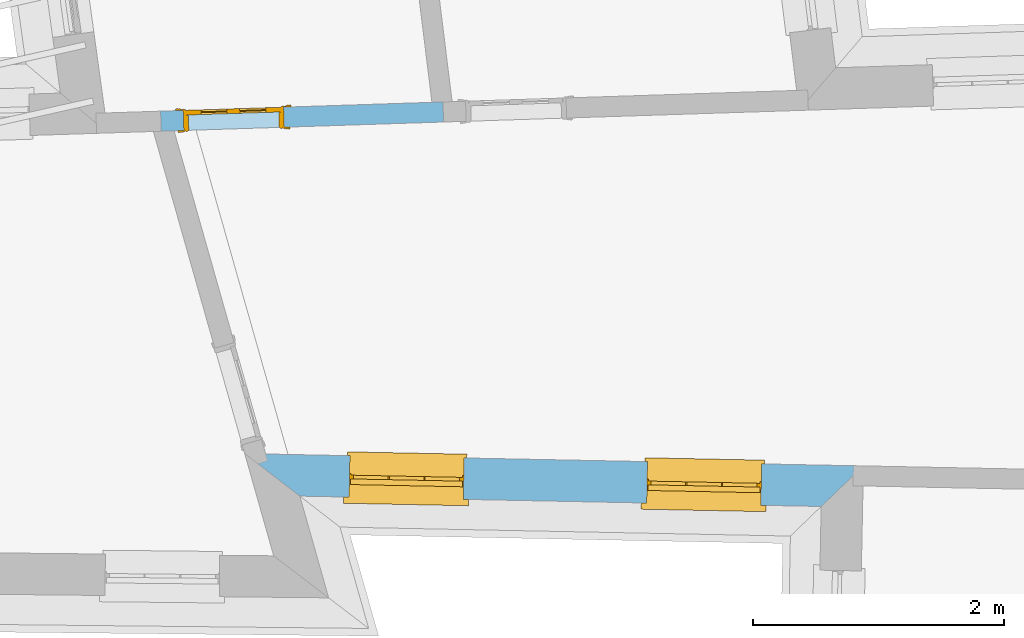
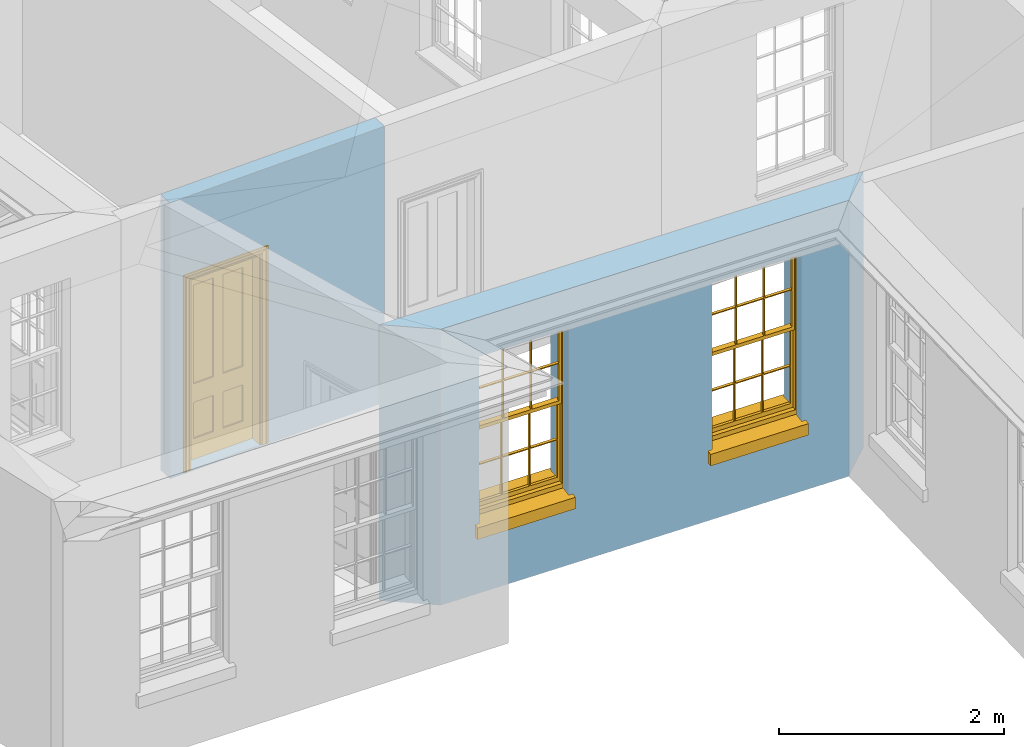
# One storey, part 4 of 11: 2 windows, 1 door, 3 openings, plus 2 elements that do not belong to this part.
"""IFC2X3 building model written with IfcOpenShell, lengths in metres."""

from ifc_helpers import new_model, si_unit, frame, origin, place, context, subcontext, project, spatial, polyline, outline, extrude, faceted_brep, material, layer, layer_set, layer_usage, element, fill, save


model = new_model("IFC2X3")

# Units and contexts
model_context = context("Model", 3, world=origin())
body_context = subcontext(model_context, "Body", "Model", "MODEL_VIEW")
ifc_project = project(units=[si_unit("PLANEANGLEUNIT", "RADIAN"), si_unit("MASSUNIT", "GRAM", prefix="KILO"), si_unit("FORCEUNIT", "NEWTON", prefix="KILO"), si_unit("LENGTHUNIT", "METRE")], contexts=[model_context])

# Site, building, storey
site_placement = place(None, origin())
site = spatial("IfcSite", under=ifc_project, at=site_placement, CompositionType="ELEMENT")
building_placement = place(None, origin())
building = spatial("IfcBuilding", under=site, at=building_placement, Name="Building plot-10", CompositionType="ELEMENT")
storey_placement = place(None, frame((0.0, 0.0, 4.6)))
storey = spatial("IfcBuildingStorey", under=building, at=storey_placement, Name="Floor 1", CompositionType="ELEMENT", Elevation=4.6)

# Wall, openings, windows
ifc_material_1 = material(Name="Masonry")
ifc_layer_1 = layer(ifc_material_1, 0.33, ventilated=False)
ifc_layer_set_1 = layer_set([ifc_layer_1], Name="My Wall")
ifc_layer_usage_1 = layer_usage(ifc_layer_set_1, "AXIS2", "NEGATIVE", 0.08)
wall_1_placement = place(storey_placement, origin())
wall_1 = element("IfcWallStandardCase", 1, at=wall_1_placement, inside=storey, material=ifc_layer_usage_1, Name="exterior", context=body_context, shape_type="SweptSolid", body=[
    extrude(outline(polyline([(46.0806293719887, 17.3535320709695), (46.5196877486523, 17.0147171959322), (50.6688922402643, 16.9320337058085), (51.0054015240496, 17.2553934156152), (46.0806293719887, 17.3535320709695)])), origin(), (0.0, 0.0, 1.0), 3.0),
])
opening_1_placement = place(storey_placement, frame((0.0, 0.0, 0.75)))
opening_1 = element("IfcOpeningElement", 2, at=opening_1_placement, cuts=wall_1, Name="Opening", ObjectType="Opening", context=body_context, shape_type="SweptSolid", body=[
    extrude(outline(polyline([(46.9113661195027, 17.0069120046544), (47.8211854894554, 16.9887815314415), (47.8277602764447, 17.3187160282375), (46.917940906492, 17.3368465014504), (46.9113661195027, 17.0069120046544)])), origin(), (0.0, 0.0, 1.0), 1.82),
])
opening_2_placement = place(storey_placement, frame((0.0, 0.0, 0.75)))
opening_2 = element("IfcOpeningElement", 3, at=opening_2_placement, cuts=wall_1, Name="Opening", ObjectType="Opening", context=body_context, shape_type="SweptSolid", body=[
    extrude(outline(polyline([(49.2797439942666, 16.9597160303385), (50.1895633642193, 16.9415855571257), (50.1961381512086, 17.2715200539217), (49.2863187812559, 17.2896505271346), (49.2797439942666, 16.9597160303385)])), origin(), (0.0, 0.0, 1.0), 1.82),
])
window_1_placement = place(storey_placement, frame((46.916347018737, 17.256862381015, 0.75), z_axis=(0.0, 0.0, 1.0), x_axis=(0.909819369952672, -0.0181304732128638, 0.0)))
window_1 = element("IfcWindow", 4, at=window_1_placement, inside=storey, Name="circulation outside window", OverallHeight=1.82, OverallWidth=0.91, context=body_context, shape_type="Brep", held_by="IfcProductRepresentation", body=[
    faceted_brep([(0.033125, -0.105, 0.975209), (0.01, -0.105, 0.975209), (0.033125, -0.105, 1.376042), (0.876875, -0.105, 0.975209), (0.876875, -0.105, 1.376042), (0.9, -0.105, 0.975209), (0.876875, -0.105, 1.386042), (0.876875, -0.105, 1.786875), (0.9, -0.105, 1.81), (0.033125, -0.105, 1.786875), (0.033125, -0.105, 1.386042), (0.01, -0.105, 1.81), (0.876875, -0.135, 1.376042), (0.876875, -0.135, 0.975209), (0.9, -0.135, 0.937083), (0.033125, -0.135, 1.786875), (0.01, -0.135, 1.81), (0.033125, -0.135, 1.386042), (0.01, -0.135, 0.937083), (0.033125, -0.135, 0.975209), (0.033125, -0.135, 1.376042), (0.876875, -0.135, 1.786875), (0.876875, -0.135, 1.386042), (0.9, -0.135, 1.81), (0.033125, -0.105, 0.937083), (0.01, -0.105, 0.937083), (0.033125, -0.105, 0.53625), (0.876875, -0.105, 0.937083), (0.876875, -0.105, 0.53625), (0.9, -0.105, 0.937083), (0.876875, -0.105, 0.52625), (0.876875, -0.105, 0.125417), (0.9, -0.105, 0.077167), (0.033125, -0.105, 0.125417), (0.033125, -0.105, 0.52625), (0.01, -0.105, 0.077167), (-0.0425, -0.25, 0.01), (-0.0425, -0.3, 0.001667), (0.0, -0.25, 0.01), (0.9525, -0.25, 0.01), (0.91, -0.25, 0.01), (0.9525, -0.3, 0.001667), (-0.02, 0.08, 0.077167), (0.0, 0.08, 0.077167), (-0.02, 0.11, 0.077167), (0.0, -0.06, 0.077167), (0.01, -0.06, 0.077167), (0.91, -0.06, 0.077167), (0.91, 0.08, 0.077167), (0.9, -0.06, 0.077167), (0.93, 0.08, 0.077167), (0.93, 0.11, 0.077167), (0.01, -0.075, 0.975209), (0.9, -0.075, 0.975209), (0.876875, -0.075, 0.125417), (0.876875, -0.075, 0.52625), (0.9, -0.075, 0.077167), (0.876875, -0.075, 0.53625), (0.876875, -0.075, 0.937083), (0.033125, -0.075, 0.125417), (0.01, -0.075, 0.077167), (0.033125, -0.075, 0.52625), (0.033125, -0.075, 0.937083), (0.033125, -0.075, 0.53625), (-0.02, 0.08, 0.052167), (-0.02, 0.11, 0.052167), (0.93, 0.11, 0.052167), (0.93, 0.08, 0.052167), (0.91, 0.08, 0.052167), (0.0, 0.08, 0.052167), (0.91, -0.15, 0.026667), (0.0, -0.15, 0.026667), (-0.0425, -0.3, -0.123333), (0.9525, -0.3, -0.123333), (-0.0425, -0.25, -0.123333), (0.9525, -0.25, -0.123333), (0.01, -0.06, 1.81), (0.9, -0.06, 1.81), (0.0, -0.06, 1.82), (0.91, -0.06, 1.82), (0.01, -0.15, 0.077167), (0.9, -0.15, 0.077167), (0.592292, -0.105, 0.125417), (0.592292, -0.075, 0.125417), (0.317708, -0.075, 0.125417), (0.317708, -0.105, 0.125417), (0.592292, -0.105, 0.53625), (0.317708, -0.105, 0.53625), (0.317708, -0.105, 0.52625), (0.592292, -0.105, 0.52625), (0.592292, -0.075, 0.53625), (0.317708, -0.075, 0.53625), (0.592292, -0.135, 1.386042), (0.592292, -0.105, 1.386042), (0.317708, -0.105, 1.386042), (0.317708, -0.135, 1.386042), (0.317708, -0.135, 1.376042), (0.592292, -0.135, 1.376042), (0.317708, -0.105, 1.376042), (0.592292, -0.105, 1.376042), (0.602292, -0.135, 1.376042), (0.592292, -0.135, 0.975209), (0.602292, -0.135, 0.975209), (0.602292, -0.105, 0.975209), (0.592292, -0.105, 0.975209), (0.602292, -0.105, 1.376042), (0.602292, -0.075, 0.53625), (0.602292, -0.105, 0.53625), (0.317708, -0.075, 0.52625), (0.307708, -0.075, 0.125417), (0.307708, -0.075, 0.52625), (0.602292, -0.075, 0.52625), (0.602292, -0.075, 0.125417), (0.592292, -0.075, 0.52625), (0.307708, -0.075, 0.53625), (0.317708, -0.075, 0.937083), (0.307708, -0.075, 0.937083), (0.602292, -0.075, 0.937083), (0.592292, -0.075, 0.937083), (0.307708, -0.105, 0.52625), (0.307708, -0.105, 0.125417), (0.307708, -0.105, 0.53625), (0.307708, -0.105, 0.937083), (0.592292, -0.105, 0.937083), (0.317708, -0.105, 0.937083), (0.602292, -0.105, 0.937083), (0.602292, -0.105, 0.52625), (0.602292, -0.105, 0.125417), (0.307708, -0.135, 1.386042), (0.307708, -0.135, 1.376042), (0.307708, -0.135, 0.975209), (0.317708, -0.135, 0.975209), (0.317708, -0.135, 1.786875), (0.307708, -0.135, 1.786875), (0.602292, -0.135, 1.786875), (0.592292, -0.135, 1.786875), (0.602292, -0.135, 1.386042), (0.602292, -0.105, 1.386042), (0.307708, -0.105, 1.386042), (0.307708, -0.105, 1.786875), (0.317708, -0.105, 1.786875), (0.592292, -0.105, 1.786875), (0.602292, -0.105, 1.786875), (0.307708, -0.105, 1.376042), (0.317708, -0.105, 0.975209), (0.307708, -0.105, 0.975209), (0.91, -0.15, 1.82), (0.9, -0.15, 1.81), (0.01, -0.15, 1.81), (0.0, -0.15, 1.82), (0.91, -0.25, 0.0), (0.0, -0.25, 0.0), (0.91, 0.08, 0.0), (0.0, 0.08, 0.0)], [[[0, 1, 2]], [[3, 4, 5]], [[6, 7, 8]], [[9, 10, 11]], [[12, 13, 14]], [[15, 16, 17]], [[18, 19, 20]], [[21, 22, 23]], [[24, 25, 26]], [[27, 28, 29]], [[30, 31, 32]], [[33, 34, 35]], [[14, 27, 29]], [[25, 24, 18]], [[36, 37, 38]], [[39, 40, 41]], [[42, 43, 44]], [[45, 46, 43]], [[47, 48, 49]], [[50, 51, 48]], [[1, 0, 52]], [[5, 53, 3]], [[54, 55, 56]], [[57, 58, 53]], [[59, 60, 61]], [[62, 63, 52]], [[48, 43, 46, 49]], [[51, 44, 43, 48]], [[64, 42, 44, 65]], [[65, 44, 51, 66]], [[66, 51, 50, 67]], [[65, 66, 68, 69]], [[60, 56, 49, 46]], [[70, 71, 38, 40]], [[37, 41, 40, 38]], [[37, 72, 73, 41]], [[74, 75, 73, 72]], [[8, 11, 76, 77]], [[76, 78, 79, 77]], [[32, 35, 80, 81]], [[81, 80, 71, 70]], [[82, 83, 84, 85]], [[86, 87, 88, 89]], [[86, 90, 91, 87]], [[92, 93, 94, 95]], [[92, 95, 96, 97]], [[96, 98, 99, 97]], [[100, 97, 101, 102]], [[103, 104, 99, 105]], [[97, 99, 104, 101]], [[102, 103, 105, 100]], [[28, 57, 106, 107]], [[108, 84, 109, 110]], [[111, 112, 83, 113]], [[114, 110, 61, 63]], [[90, 113, 108, 91]], [[115, 91, 114, 116]], [[117, 106, 90, 118]], [[111, 106, 57, 55]], [[119, 110, 109, 120]], [[34, 61, 110, 119]], [[89, 113, 83, 82]], [[88, 108, 113, 89]], [[85, 84, 108, 88]], [[121, 114, 63, 26]], [[122, 116, 114, 121]], [[123, 118, 90, 86]], [[87, 91, 115, 124]], [[107, 106, 117, 125]], [[126, 111, 55, 30]], [[127, 112, 111, 126]], [[126, 30, 28, 107]], [[88, 119, 120, 85]], [[126, 89, 82, 127]], [[125, 123, 86, 107]], [[121, 26, 34, 119]], [[124, 122, 121, 87]], [[128, 17, 20, 129]], [[96, 129, 130, 131]], [[132, 133, 128, 95]], [[134, 135, 92, 136]], [[100, 12, 22, 136]], [[137, 6, 4, 105]], [[94, 138, 139, 140]], [[137, 93, 141, 142]], [[99, 98, 94, 93]], [[143, 2, 10, 138]], [[144, 145, 143, 98]], [[129, 143, 145, 130]], [[20, 2, 143, 129]], [[131, 144, 98, 96]], [[128, 138, 10, 17]], [[133, 139, 138, 128]], [[135, 141, 93, 92]], [[95, 94, 140, 132]], [[22, 6, 137, 136]], [[136, 137, 142, 134]], [[100, 105, 4, 12]], [[107, 86, 89, 126]], [[106, 111, 113, 90]], [[91, 108, 110, 114]], [[87, 121, 119, 88]], [[97, 100, 136, 92]], [[129, 96, 95, 128]], [[98, 143, 138, 94]], [[105, 99, 93, 137]], [[131, 101, 104, 144]], [[124, 115, 118, 123]], [[132, 140, 141, 135]], [[120, 109, 59, 33]], [[15, 9, 139, 133]], [[134, 142, 7, 21]], [[31, 54, 112, 127]], [[36, 74, 72, 37]], [[39, 41, 73, 75]], [[18, 14, 101, 131]], [[23, 16, 132, 135]], [[83, 56, 60, 84]], [[52, 53, 118, 115]], [[53, 52, 144, 104]], [[11, 8, 141, 140]], [[14, 18, 124, 123]], [[2, 1, 11, 10]], [[8, 5, 4, 6]], [[57, 53, 56, 55]], [[60, 52, 63, 61]], [[26, 25, 35, 34]], [[32, 29, 28, 30]], [[14, 23, 22, 12]], [[18, 20, 17, 16]], [[19, 0, 2, 20]], [[17, 10, 9, 15]], [[12, 4, 3, 13]], [[21, 7, 6, 22]], [[27, 58, 57, 28]], [[30, 55, 54, 31]], [[33, 59, 61, 34]], [[26, 63, 62, 24]], [[5, 8, 77, 53]], [[76, 11, 1, 52]], [[46, 45, 78, 76]], [[49, 77, 79, 47]], [[70, 146, 147, 81]], [[71, 80, 148, 149]], [[19, 130, 145, 0]], [[102, 13, 3, 103]], [[116, 122, 24, 62]], [[29, 32, 81, 14]], [[80, 35, 25, 18]], [[60, 46, 76, 52]], [[77, 49, 56, 53]], [[23, 14, 81, 147]], [[16, 148, 80, 18]], [[35, 85, 120]], [[120, 33, 35]], [[127, 82, 32]], [[32, 31, 127]], [[32, 82, 85, 35]], [[102, 101, 14]], [[14, 13, 102]], [[18, 131, 130]], [[130, 19, 18]], [[134, 21, 23]], [[23, 135, 134]], [[16, 15, 133]], [[133, 132, 16]], [[11, 140, 139]], [[139, 9, 11]], [[142, 141, 8]], [[8, 7, 142]], [[23, 147, 148, 16]], [[146, 149, 148, 147]], [[52, 115, 116]], [[116, 62, 52]], [[118, 53, 117]], [[58, 117, 53]], [[27, 125, 117, 58]], [[56, 83, 112]], [[112, 54, 56]], [[109, 84, 60]], [[60, 59, 109]], [[125, 27, 14]], [[14, 123, 125]], [[122, 124, 18]], [[18, 24, 122]], [[145, 144, 52]], [[52, 0, 145]], [[103, 3, 53]], [[53, 104, 103]], [[79, 78, 149, 146]], [[78, 45, 71, 149]], [[146, 70, 47, 79]], [[150, 75, 74, 151]], [[68, 66, 67]], [[48, 68, 67, 50]], [[69, 64, 65]], [[42, 64, 69, 43]], [[69, 68, 152, 153]], [[70, 68, 48, 47]], [[150, 152, 68, 70]], [[43, 69, 71, 45]], [[69, 153, 151, 71]], [[152, 150, 151, 153]], [[38, 151, 74, 36]], [[71, 151, 38]], [[39, 75, 150, 40]], [[40, 150, 70]]]),
])
fill(opening_1, window_1)
window_2_placement = place(storey_placement, frame((49.2847248935009, 17.2096664066992, 0.75), z_axis=(0.0, 0.0, 1.0), x_axis=(0.909819369952672, -0.0181304732128638, 0.0)))
window_2 = element("IfcWindow", 5, at=window_2_placement, inside=storey, Name="circulation outside window", OverallHeight=1.82, OverallWidth=0.91, context=body_context, shape_type="Brep", held_by="IfcProductRepresentation", body=[
    faceted_brep([(0.033125, -0.105, 0.975209), (0.01, -0.105, 0.975209), (0.033125, -0.105, 1.376042), (0.876875, -0.105, 0.975209), (0.876875, -0.105, 1.376042), (0.9, -0.105, 0.975209), (0.876875, -0.105, 1.386042), (0.876875, -0.105, 1.786875), (0.9, -0.105, 1.81), (0.033125, -0.105, 1.786875), (0.033125, -0.105, 1.386042), (0.01, -0.105, 1.81), (0.876875, -0.135, 1.376042), (0.876875, -0.135, 0.975209), (0.9, -0.135, 0.937083), (0.033125, -0.135, 1.786875), (0.01, -0.135, 1.81), (0.033125, -0.135, 1.386042), (0.01, -0.135, 0.937083), (0.033125, -0.135, 0.975209), (0.033125, -0.135, 1.376042), (0.876875, -0.135, 1.786875), (0.876875, -0.135, 1.386042), (0.9, -0.135, 1.81), (0.033125, -0.105, 0.937083), (0.01, -0.105, 0.937083), (0.033125, -0.105, 0.53625), (0.876875, -0.105, 0.937083), (0.876875, -0.105, 0.53625), (0.9, -0.105, 0.937083), (0.876875, -0.105, 0.52625), (0.876875, -0.105, 0.125417), (0.9, -0.105, 0.077167), (0.033125, -0.105, 0.125417), (0.033125, -0.105, 0.52625), (0.01, -0.105, 0.077167), (-0.0425, -0.25, 0.01), (-0.0425, -0.3, 0.001667), (0.0, -0.25, 0.01), (0.9525, -0.25, 0.01), (0.91, -0.25, 0.01), (0.9525, -0.3, 0.001667), (-0.02, 0.08, 0.077167), (0.0, 0.08, 0.077167), (-0.02, 0.11, 0.077167), (0.0, -0.06, 0.077167), (0.01, -0.06, 0.077167), (0.91, -0.06, 0.077167), (0.91, 0.08, 0.077167), (0.9, -0.06, 0.077167), (0.93, 0.08, 0.077167), (0.93, 0.11, 0.077167), (0.01, -0.075, 0.975209), (0.9, -0.075, 0.975209), (0.876875, -0.075, 0.125417), (0.876875, -0.075, 0.52625), (0.9, -0.075, 0.077167), (0.876875, -0.075, 0.53625), (0.876875, -0.075, 0.937083), (0.033125, -0.075, 0.125417), (0.01, -0.075, 0.077167), (0.033125, -0.075, 0.52625), (0.033125, -0.075, 0.937083), (0.033125, -0.075, 0.53625), (-0.02, 0.08, 0.052167), (-0.02, 0.11, 0.052167), (0.93, 0.11, 0.052167), (0.93, 0.08, 0.052167), (0.91, 0.08, 0.052167), (0.0, 0.08, 0.052167), (0.91, -0.15, 0.026667), (0.0, -0.15, 0.026667), (-0.0425, -0.3, -0.123333), (0.9525, -0.3, -0.123333), (-0.0425, -0.25, -0.123333), (0.9525, -0.25, -0.123333), (0.01, -0.06, 1.81), (0.9, -0.06, 1.81), (0.0, -0.06, 1.82), (0.91, -0.06, 1.82), (0.01, -0.15, 0.077167), (0.9, -0.15, 0.077167), (0.592292, -0.105, 0.125417), (0.592292, -0.075, 0.125417), (0.317708, -0.075, 0.125417), (0.317708, -0.105, 0.125417), (0.592292, -0.105, 0.53625), (0.317708, -0.105, 0.53625), (0.317708, -0.105, 0.52625), (0.592292, -0.105, 0.52625), (0.592292, -0.075, 0.53625), (0.317708, -0.075, 0.53625), (0.592292, -0.135, 1.386042), (0.592292, -0.105, 1.386042), (0.317708, -0.105, 1.386042), (0.317708, -0.135, 1.386042), (0.317708, -0.135, 1.376042), (0.592292, -0.135, 1.376042), (0.317708, -0.105, 1.376042), (0.592292, -0.105, 1.376042), (0.602292, -0.135, 1.376042), (0.592292, -0.135, 0.975209), (0.602292, -0.135, 0.975209), (0.602292, -0.105, 0.975209), (0.592292, -0.105, 0.975209), (0.602292, -0.105, 1.376042), (0.602292, -0.075, 0.53625), (0.602292, -0.105, 0.53625), (0.317708, -0.075, 0.52625), (0.307708, -0.075, 0.125417), (0.307708, -0.075, 0.52625), (0.602292, -0.075, 0.52625), (0.602292, -0.075, 0.125417), (0.592292, -0.075, 0.52625), (0.307708, -0.075, 0.53625), (0.317708, -0.075, 0.937083), (0.307708, -0.075, 0.937083), (0.602292, -0.075, 0.937083), (0.592292, -0.075, 0.937083), (0.307708, -0.105, 0.52625), (0.307708, -0.105, 0.125417), (0.307708, -0.105, 0.53625), (0.307708, -0.105, 0.937083), (0.592292, -0.105, 0.937083), (0.317708, -0.105, 0.937083), (0.602292, -0.105, 0.937083), (0.602292, -0.105, 0.52625), (0.602292, -0.105, 0.125417), (0.307708, -0.135, 1.386042), (0.307708, -0.135, 1.376042), (0.307708, -0.135, 0.975209), (0.317708, -0.135, 0.975209), (0.317708, -0.135, 1.786875), (0.307708, -0.135, 1.786875), (0.602292, -0.135, 1.786875), (0.592292, -0.135, 1.786875), (0.602292, -0.135, 1.386042), (0.602292, -0.105, 1.386042), (0.307708, -0.105, 1.386042), (0.307708, -0.105, 1.786875), (0.317708, -0.105, 1.786875), (0.592292, -0.105, 1.786875), (0.602292, -0.105, 1.786875), (0.307708, -0.105, 1.376042), (0.317708, -0.105, 0.975209), (0.307708, -0.105, 0.975209), (0.91, -0.15, 1.82), (0.9, -0.15, 1.81), (0.01, -0.15, 1.81), (0.0, -0.15, 1.82), (0.91, -0.25, 0.0), (0.0, -0.25, 0.0), (0.91, 0.08, 0.0), (0.0, 0.08, 0.0)], [[[0, 1, 2]], [[3, 4, 5]], [[6, 7, 8]], [[9, 10, 11]], [[12, 13, 14]], [[15, 16, 17]], [[18, 19, 20]], [[21, 22, 23]], [[24, 25, 26]], [[27, 28, 29]], [[30, 31, 32]], [[33, 34, 35]], [[14, 27, 29]], [[25, 24, 18]], [[36, 37, 38]], [[39, 40, 41]], [[42, 43, 44]], [[45, 46, 43]], [[47, 48, 49]], [[50, 51, 48]], [[1, 0, 52]], [[5, 53, 3]], [[54, 55, 56]], [[57, 58, 53]], [[59, 60, 61]], [[62, 63, 52]], [[48, 43, 46, 49]], [[51, 44, 43, 48]], [[64, 42, 44, 65]], [[65, 44, 51, 66]], [[66, 51, 50, 67]], [[65, 66, 68, 69]], [[60, 56, 49, 46]], [[70, 71, 38, 40]], [[37, 41, 40, 38]], [[37, 72, 73, 41]], [[74, 75, 73, 72]], [[8, 11, 76, 77]], [[76, 78, 79, 77]], [[32, 35, 80, 81]], [[81, 80, 71, 70]], [[82, 83, 84, 85]], [[86, 87, 88, 89]], [[86, 90, 91, 87]], [[92, 93, 94, 95]], [[92, 95, 96, 97]], [[96, 98, 99, 97]], [[100, 97, 101, 102]], [[103, 104, 99, 105]], [[97, 99, 104, 101]], [[102, 103, 105, 100]], [[28, 57, 106, 107]], [[108, 84, 109, 110]], [[111, 112, 83, 113]], [[114, 110, 61, 63]], [[90, 113, 108, 91]], [[115, 91, 114, 116]], [[117, 106, 90, 118]], [[111, 106, 57, 55]], [[119, 110, 109, 120]], [[34, 61, 110, 119]], [[89, 113, 83, 82]], [[88, 108, 113, 89]], [[85, 84, 108, 88]], [[121, 114, 63, 26]], [[122, 116, 114, 121]], [[123, 118, 90, 86]], [[87, 91, 115, 124]], [[107, 106, 117, 125]], [[126, 111, 55, 30]], [[127, 112, 111, 126]], [[126, 30, 28, 107]], [[88, 119, 120, 85]], [[126, 89, 82, 127]], [[125, 123, 86, 107]], [[121, 26, 34, 119]], [[124, 122, 121, 87]], [[128, 17, 20, 129]], [[96, 129, 130, 131]], [[132, 133, 128, 95]], [[134, 135, 92, 136]], [[100, 12, 22, 136]], [[137, 6, 4, 105]], [[94, 138, 139, 140]], [[137, 93, 141, 142]], [[99, 98, 94, 93]], [[143, 2, 10, 138]], [[144, 145, 143, 98]], [[129, 143, 145, 130]], [[20, 2, 143, 129]], [[131, 144, 98, 96]], [[128, 138, 10, 17]], [[133, 139, 138, 128]], [[135, 141, 93, 92]], [[95, 94, 140, 132]], [[22, 6, 137, 136]], [[136, 137, 142, 134]], [[100, 105, 4, 12]], [[107, 86, 89, 126]], [[106, 111, 113, 90]], [[91, 108, 110, 114]], [[87, 121, 119, 88]], [[97, 100, 136, 92]], [[129, 96, 95, 128]], [[98, 143, 138, 94]], [[105, 99, 93, 137]], [[131, 101, 104, 144]], [[124, 115, 118, 123]], [[132, 140, 141, 135]], [[120, 109, 59, 33]], [[15, 9, 139, 133]], [[134, 142, 7, 21]], [[31, 54, 112, 127]], [[36, 74, 72, 37]], [[39, 41, 73, 75]], [[18, 14, 101, 131]], [[23, 16, 132, 135]], [[83, 56, 60, 84]], [[52, 53, 118, 115]], [[53, 52, 144, 104]], [[11, 8, 141, 140]], [[14, 18, 124, 123]], [[2, 1, 11, 10]], [[8, 5, 4, 6]], [[57, 53, 56, 55]], [[60, 52, 63, 61]], [[26, 25, 35, 34]], [[32, 29, 28, 30]], [[14, 23, 22, 12]], [[18, 20, 17, 16]], [[19, 0, 2, 20]], [[17, 10, 9, 15]], [[12, 4, 3, 13]], [[21, 7, 6, 22]], [[27, 58, 57, 28]], [[30, 55, 54, 31]], [[33, 59, 61, 34]], [[26, 63, 62, 24]], [[5, 8, 77, 53]], [[76, 11, 1, 52]], [[46, 45, 78, 76]], [[49, 77, 79, 47]], [[70, 146, 147, 81]], [[71, 80, 148, 149]], [[19, 130, 145, 0]], [[102, 13, 3, 103]], [[116, 122, 24, 62]], [[29, 32, 81, 14]], [[80, 35, 25, 18]], [[60, 46, 76, 52]], [[77, 49, 56, 53]], [[23, 14, 81, 147]], [[16, 148, 80, 18]], [[35, 85, 120]], [[120, 33, 35]], [[127, 82, 32]], [[32, 31, 127]], [[32, 82, 85, 35]], [[102, 101, 14]], [[14, 13, 102]], [[18, 131, 130]], [[130, 19, 18]], [[134, 21, 23]], [[23, 135, 134]], [[16, 15, 133]], [[133, 132, 16]], [[11, 140, 139]], [[139, 9, 11]], [[142, 141, 8]], [[8, 7, 142]], [[23, 147, 148, 16]], [[146, 149, 148, 147]], [[52, 115, 116]], [[116, 62, 52]], [[118, 53, 117]], [[58, 117, 53]], [[27, 125, 117, 58]], [[56, 83, 112]], [[112, 54, 56]], [[109, 84, 60]], [[60, 59, 109]], [[125, 27, 14]], [[14, 123, 125]], [[122, 124, 18]], [[18, 24, 122]], [[145, 144, 52]], [[52, 0, 145]], [[103, 3, 53]], [[53, 104, 103]], [[79, 78, 149, 146]], [[78, 45, 71, 149]], [[146, 70, 47, 79]], [[150, 75, 74, 151]], [[68, 66, 67]], [[48, 68, 67, 50]], [[69, 64, 65]], [[42, 64, 69, 43]], [[69, 68, 152, 153]], [[70, 68, 48, 47]], [[150, 152, 68, 70]], [[43, 69, 71, 45]], [[69, 153, 151, 71]], [[152, 150, 151, 153]], [[38, 151, 74, 36]], [[71, 151, 38]], [[39, 75, 150, 40]], [[40, 150, 70]]]),
])
fill(opening_2, window_2)

# Wall, opening, door
ifc_material_2 = material(Name="Masonry")
ifc_layer_2 = layer(ifc_material_2, 0.16, ventilated=False)
ifc_layer_set_2 = layer_set([ifc_layer_2], Name="My Wall")
ifc_layer_usage_2 = layer_usage(ifc_layer_set_2, "AXIS2", "NEGATIVE", 0.08)
wall_2_placement = place(storey_placement, origin())
wall_2 = element("IfcWallStandardCase", 6, at=wall_2_placement, inside=storey, material=ifc_layer_usage_2, Name="interior", context=body_context, shape_type="SweptSolid", body=[
    extrude(outline(polyline([(45.4112260653986, 20.0788372363305), (45.416435890318, 19.9189220784363), (47.6638318559474, 19.9921392747288), (47.658622031028, 20.152054432623), (45.4112260653986, 20.0788372363305)])), origin(), (0.0, 0.0, 1.0), 3.0),
])
opening_3_placement = place(storey_placement, frame((0.0, 0.0, 0.0199999999999996)))
opening_3 = element("IfcOpeningElement", 7, at=opening_3_placement, cuts=wall_2, Name="Opening", ObjectType="Opening", context=body_context, shape_type="SweptSolid", body=[
    extrude(outline(polyline([(45.596340442949, 19.9247831314708), (46.3959162324197, 19.9508322560682), (46.3907064075002, 20.1107474139623), (45.5911306180295, 20.0846982893649), (45.596340442949, 19.9247831314708)])), origin(), (0.0, 0.0, 1.0), 2.1),
])
door_placement = place(storey_placement, frame((45.5937355304892, 20.0047407104178, 0.0199999999999996), z_axis=(0.0, 0.0, 1.0), x_axis=(0.799575789470708, 0.0260491245974137, 0.0)))
door = element("IfcDoor", 8, at=door_placement, inside=storey, Name="bedroom inside door", OverallHeight=2.1, OverallWidth=0.8, context=body_context, shape_type="Brep", held_by="IfcProductRepresentation", body=[
    faceted_brep([(0.773, 0.08, 1.895), (0.66, 0.08, 1.895), (0.66, 0.08, 2.073), (0.773, 0.08, 2.073), (0.773, 0.08, 0.82), (0.66, 0.08, 0.82), (0.45, 0.08, 1.895), (0.45, 0.08, 2.073), (0.773, 0.08, 0.62), (0.66, 0.08, 0.62), (0.66, 0.065, 0.82), (0.66, 0.065, 1.895), (0.45, 0.065, 1.895), (0.35, 0.08, 1.895), (0.35, 0.08, 2.073), (0.773, 0.08, 0.225), (0.66, 0.08, 0.225), (0.45, 0.08, 0.62), (0.45, 0.08, 0.82), (0.45, 0.065, 0.82), (0.35, 0.08, 0.82), (0.14, 0.08, 2.073), (0.14, 0.08, 1.895), (0.773, 0.08, 0.0), (0.66, 0.08, 0.0), (0.66, 0.065, 0.225), (0.66, 0.065, 0.62), (0.45, 0.065, 0.62), (0.35, 0.08, 0.62), (0.35, 0.065, 0.82), (0.35, 0.065, 1.895), (0.14, 0.065, 1.895), (0.027, 0.08, 2.073), (0.027, 0.08, 1.895), (0.773, 0.042, 0.0), (0.66, 0.042, 0.0), (0.45, 0.08, 0.0), (0.45, 0.08, 0.225), (0.45, 0.065, 0.225), (0.35, 0.08, 0.225), (0.14, 0.08, 0.82), (0.14, 0.08, 0.62), (0.14, 0.065, 0.82), (0.027, 0.08, 0.82), (0.773, 0.042, 0.225), (0.66, 0.042, 0.225), (0.45, 0.042, 0.0), (0.35, 0.08, 0.0), (0.35, 0.065, 0.225), (0.35, 0.065, 0.62), (0.14, 0.065, 0.62), (0.027, 0.08, 0.62), (0.773, 0.042, 0.62), (0.66, 0.042, 0.62), (0.45, 0.042, 0.225), (0.35, 0.042, 0.0), (0.14, 0.08, 0.225), (0.14, 0.08, 0.0), (0.14, 0.065, 0.225), (0.027, 0.08, 0.225), (0.773, 0.042, 0.82), (0.66, 0.042, 0.82), (0.66, 0.057, 0.62), (0.66, 0.057, 0.225), (0.45, 0.057, 0.225), (0.35, 0.042, 0.225), (0.14, 0.042, 0.0), (0.027, 0.08, 0.0), (0.773, 0.042, 1.895), (0.66, 0.042, 1.895), (0.45, 0.042, 0.62), (0.45, 0.042, 0.82), (0.45, 0.057, 0.62), (0.35, 0.042, 0.62), (0.14, 0.042, 0.225), (0.027, 0.042, 0.0), (0.773, 0.042, 2.073), (0.66, 0.042, 2.073), (0.66, 0.057, 1.895), (0.66, 0.057, 0.82), (0.45, 0.057, 0.82), (0.35, 0.042, 0.82), (0.35, 0.057, 0.62), (0.35, 0.057, 0.225), (0.14, 0.057, 0.225), (0.027, 0.042, 0.225), (0.45, 0.042, 1.895), (0.45, 0.042, 2.073), (0.45, 0.057, 1.895), (0.35, 0.042, 1.895), (0.14, 0.042, 0.82), (0.14, 0.042, 0.62), (0.14, 0.057, 0.62), (0.027, 0.042, 0.62), (0.35, 0.042, 2.073), (0.35, 0.057, 1.895), (0.35, 0.057, 0.82), (0.14, 0.057, 0.82), (0.027, 0.042, 0.82), (0.14, 0.042, 2.073), (0.14, 0.042, 1.895), (0.14, 0.057, 1.895), (0.027, 0.042, 1.895), (0.027, 0.042, 2.073), (0.02, 0.085, 0.0), (0.005, 0.09, 0.0), (0.005, 0.09, 2.095), (0.02, 0.085, 2.08), (0.02, 0.08, 0.0), (0.0, 0.085, 0.0), (0.0, 0.085, 2.1), (0.795, 0.09, 2.095), (0.78, 0.085, 2.08), (0.02, 0.08, 2.08), (0.0, 0.08, 0.0), (-0.032, 0.095, 0.0), (-0.032, 0.095, 2.132), (0.8, 0.085, 2.1), (0.795, 0.09, 0.0), (0.78, 0.085, 0.0), (0.78, 0.08, 2.08), (0.04, 0.04, 0.0), (0.025, 0.04, 0.0), (0.025, 0.04, 2.075), (0.04, 0.04, 2.06), (-0.04, 0.09, 0.0), (-0.04, 0.09, 2.14), (0.832, 0.095, 2.132), (0.8, 0.085, 0.0), (0.78, 0.08, 0.0), (0.8, 0.08, 0.0), (0.86, 0.08, 0.0), (0.86, 0.08, 2.16), (0.8, 0.08, 2.1), (-0.06, 0.08, 2.16), (0.0, 0.08, 2.1), (-0.06, 0.08, 0.0), (-0.04, 0.095, 0.0), (-0.04, 0.095, 2.14), (0.84, 0.09, 2.14), (0.832, 0.095, 0.0), (0.84, 0.09, 0.0), (0.86, 0.095, 0.0), (0.86, 0.095, 2.16), (-0.06, 0.095, 2.16), (-0.06, 0.095, 0.0), (0.84, 0.095, 0.0), (0.84, 0.095, 2.14), (-0.025, -0.095, 0.0), (-0.025, -0.09, 0.0), (-0.025, -0.09, 2.125), (-0.025, -0.095, 2.125), (-0.017, -0.095, 0.0), (-0.017, -0.095, 2.117), (0.825, -0.09, 2.125), (0.825, -0.095, 2.125), (0.825, -0.095, 0.0), (0.845, -0.095, 0.0), (-0.045, -0.095, 2.145), (-0.045, -0.095, 0.0), (0.845, -0.095, 2.145), (0.015, -0.085, 0.0), (0.015, -0.085, 2.085), (0.817, -0.095, 2.117), (0.825, -0.09, 0.0), (0.845, -0.08, 0.0), (0.845, -0.08, 2.145), (-0.045, -0.08, 2.145), (-0.045, -0.08, 0.0), (0.02, -0.09, 0.0), (0.02, -0.09, 2.08), (0.785, -0.085, 2.085), (0.817, -0.095, 0.0), (0.8, -0.08, 0.0), (0.8, -0.08, 2.1), (0.0, -0.08, 2.1), (0.0, -0.08, 0.0), (0.035, -0.085, 0.0), (0.035, -0.085, 2.065), (0.78, -0.09, 2.08), (0.785, -0.085, 0.0), (0.775, 0.04, 2.075), (0.76, 0.04, 2.06), (0.035, -0.08, 2.065), (0.035, -0.08, 0.0), (0.765, -0.085, 2.065), (0.78, -0.09, 0.0), (0.765, -0.08, 0.0), (0.765, -0.08, 2.065), (0.765, -0.085, 0.0), (0.04, -0.08, 2.06), (0.04, -0.08, 0.0), (0.76, -0.08, 2.06), (0.76, -0.08, 0.0), (0.76, 0.04, 0.0), (0.775, 0.04, 0.0), (0.025, 0.08, 0.0), (0.025, 0.08, 2.075), (0.775, 0.08, 0.0), (0.775, 0.08, 2.075)], [[[0, 1, 2, 3]], [[1, 0, 4, 5]], [[1, 6, 7, 2]], [[8, 9, 5, 4]], [[1, 5, 10, 11]], [[6, 1, 11, 12]], [[6, 13, 14, 7]], [[15, 16, 9, 8]], [[9, 17, 18, 5]], [[5, 18, 19, 10]], [[10, 19, 12, 11]], [[18, 6, 12, 19]], [[18, 20, 13, 6]], [[21, 14, 13, 22]], [[23, 24, 16, 15]], [[9, 16, 25, 26]], [[17, 9, 26, 27]], [[17, 28, 20, 18]], [[13, 20, 29, 30]], [[22, 13, 30, 31]], [[32, 21, 22, 33]], [[34, 35, 24, 23]], [[24, 36, 37, 16]], [[16, 37, 38, 25]], [[25, 38, 27, 26]], [[37, 17, 27, 38]], [[37, 39, 28, 17]], [[40, 20, 28, 41]], [[20, 40, 42, 29]], [[31, 30, 29, 42]], [[40, 22, 31, 42]], [[33, 22, 40, 43]], [[35, 34, 44, 45]], [[35, 46, 36, 24]], [[36, 47, 39, 37]], [[28, 39, 48, 49]], [[41, 28, 49, 50]], [[43, 40, 41, 51]], [[45, 44, 52, 53]], [[46, 35, 45, 54]], [[46, 55, 47, 36]], [[56, 39, 47, 57]], [[39, 56, 58, 48]], [[50, 49, 48, 58]], [[56, 41, 50, 58]], [[51, 41, 56, 59]], [[53, 52, 60, 61]], [[45, 53, 62, 63]], [[54, 45, 63, 64]], [[55, 46, 54, 65]], [[55, 66, 57, 47]], [[59, 56, 57, 67]], [[61, 60, 68, 69]], [[70, 53, 61, 71]], [[53, 70, 72, 62]], [[72, 64, 63, 62]], [[70, 54, 64, 72]], [[65, 54, 70, 73]], [[65, 74, 66, 55]], [[67, 57, 66, 75]], [[69, 68, 76, 77]], [[61, 69, 78, 79]], [[71, 61, 79, 80]], [[73, 70, 71, 81]], [[65, 73, 82, 83]], [[74, 65, 83, 84]], [[74, 85, 75, 66]], [[86, 69, 77, 87]], [[69, 86, 88, 78]], [[88, 80, 79, 78]], [[86, 71, 80, 88]], [[81, 71, 86, 89]], [[73, 81, 90, 91]], [[73, 91, 92, 82]], [[83, 82, 92, 84]], [[91, 74, 84, 92]], [[91, 93, 85, 74]], [[89, 86, 87, 94]], [[81, 89, 95, 96]], [[90, 81, 96, 97]], [[90, 98, 93, 91]], [[94, 99, 100, 89]], [[89, 100, 101, 95]], [[101, 97, 96, 95]], [[100, 90, 97, 101]], [[100, 102, 98, 90]], [[99, 103, 102, 100]], [[32, 103, 99, 21]], [[102, 103, 32, 33]], [[98, 102, 33, 43]], [[21, 99, 94, 14]], [[94, 87, 7, 14]], [[7, 87, 77, 2]], [[76, 3, 2, 77]], [[43, 51, 93, 98]], [[51, 59, 85, 93]], [[67, 75, 85, 59]], [[34, 23, 15, 44]], [[44, 15, 8, 52]], [[52, 8, 4, 60]], [[0, 68, 60, 4]], [[0, 3, 76, 68]], [[104, 105, 106, 107]], [[104, 108, 109, 105]], [[105, 109, 110, 106]], [[107, 106, 111, 112]], [[107, 113, 108, 104]], [[114, 109, 108]], [[109, 115, 116, 110]], [[106, 110, 117, 111]], [[112, 111, 118, 119]], [[113, 107, 112, 120]], [[121, 122, 123, 124]], [[115, 109, 114, 125]], [[115, 125, 126, 116]], [[110, 116, 127, 117]], [[111, 117, 128, 118]], [[118, 128, 129, 119]], [[120, 112, 119, 129]], [[130, 129, 128]], [[130, 131, 132, 133]], [[133, 132, 134, 135]], [[135, 134, 136, 114]], [[136, 125, 114]], [[125, 137, 138, 126]], [[116, 126, 139, 127]], [[117, 127, 140, 128]], [[141, 130, 128, 140]], [[131, 130, 141]], [[131, 142, 143, 132]], [[132, 143, 144, 134]], [[134, 144, 145, 136]], [[137, 125, 136, 145]], [[143, 142, 146]], [[143, 146, 147]], [[137, 145, 144]], [[143, 147, 138]], [[138, 137, 144]], [[143, 138, 144]], [[126, 138, 147, 139]], [[127, 139, 141, 140]], [[142, 131, 141, 146]], [[139, 147, 146, 141]], [[148, 149, 150, 151]], [[149, 152, 153, 150]], [[151, 150, 154, 155]], [[155, 156, 157]], [[158, 159, 148]], [[158, 148, 151]], [[155, 157, 160]], [[158, 151, 155]], [[155, 160, 158]], [[152, 161, 162, 153]], [[150, 153, 163, 154]], [[155, 154, 164, 156]], [[156, 164, 165, 157]], [[157, 165, 166, 160]], [[160, 166, 167, 158]], [[158, 167, 168, 159]], [[161, 169, 170, 162]], [[153, 162, 171, 163]], [[154, 163, 172, 164]], [[165, 164, 173]], [[165, 173, 174, 166]], [[166, 174, 175, 167]], [[167, 175, 176, 168]], [[169, 177, 178, 170]], [[162, 170, 179, 171]], [[163, 171, 180, 172]], [[172, 180, 173, 164]], [[124, 123, 181, 182]], [[183, 178, 177, 184]], [[170, 178, 185, 179]], [[171, 179, 186, 180]], [[187, 173, 180]], [[185, 188, 187, 189]], [[188, 185, 178, 183]], [[179, 185, 189, 186]], [[189, 187, 180, 186]], [[190, 183, 184, 191]], [[192, 188, 183, 190]], [[191, 184, 122, 121]], [[124, 190, 191, 121]], [[193, 187, 188, 192]], [[182, 192, 190, 124]], [[184, 176, 122]], [[194, 195, 187, 193]], [[192, 182, 194, 193]], [[161, 176, 184]], [[114, 108, 122, 176]], [[173, 187, 195]], [[152, 149, 176, 161]], [[169, 161, 184, 177]], [[196, 122, 108]], [[176, 175, 135, 114]], [[173, 195, 129, 130]], [[176, 149, 168]], [[123, 122, 196, 197]], [[196, 108, 113, 197]], [[175, 174, 133, 135]], [[198, 129, 195]], [[133, 174, 173, 130]], [[159, 168, 149, 148]], [[181, 123, 197, 199]], [[197, 113, 120, 199]], [[199, 120, 129, 198]], [[195, 181, 199, 198]], [[195, 194, 182, 181]]]),
])
fill(opening_3, door)

save(model, "model.ifc")
